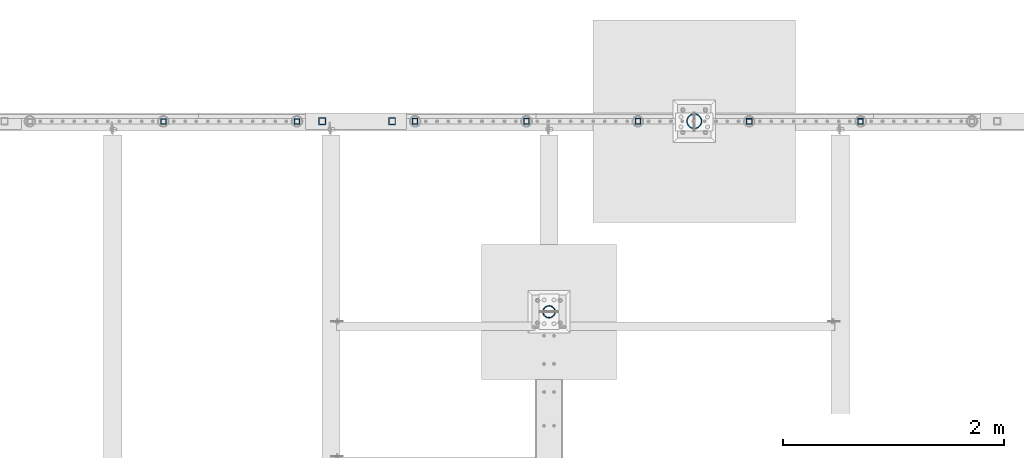
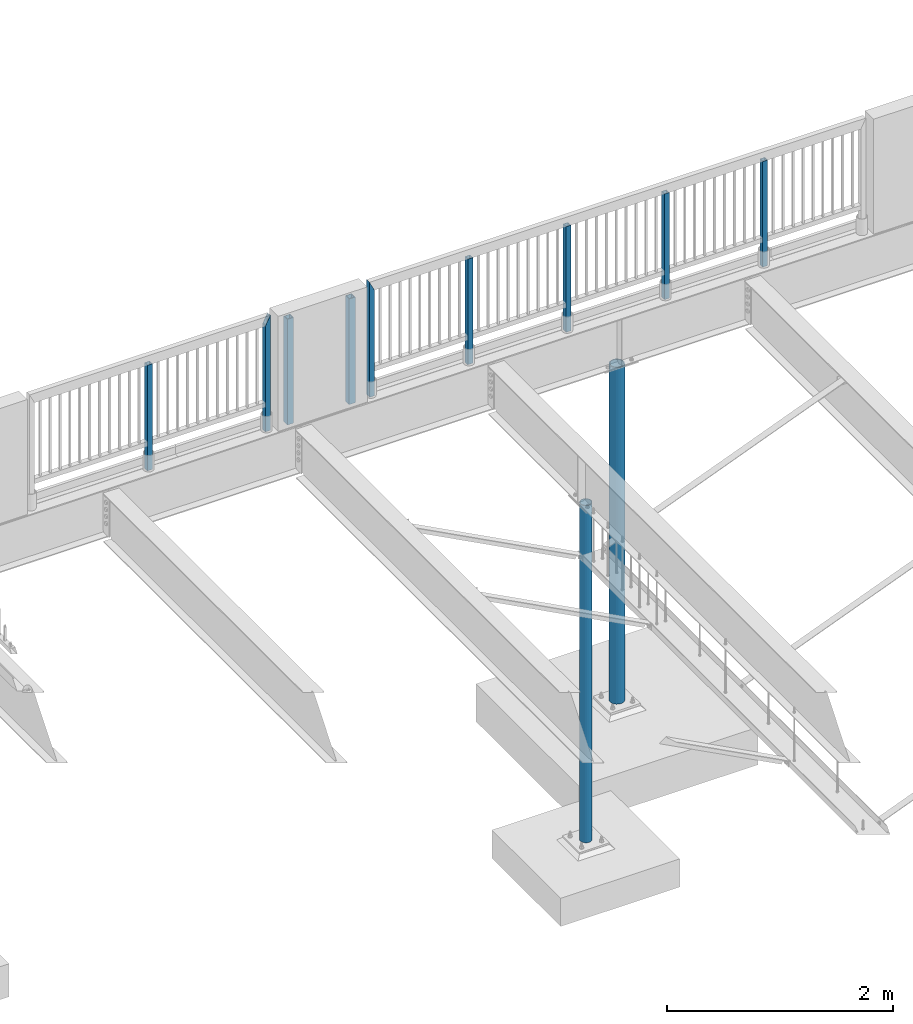
# One storey, part 127 of 975: 11 columns.
"""IFC2X3 building model written with IfcOpenShell, lengths in millimetres."""

from ifc_helpers import new_model, si_unit, frame, origin_with_axes, place, context, subcontext, project, spatial, faceted_brep, material, type_object, element, save


model = new_model("IFC2X3")

# Units and contexts
model_context = context("Model", 3, precision=1e-05, world=origin_with_axes())
body_context = subcontext(model_context, "Body", "Model", "MODEL_VIEW")
ifc_project = project(units=[si_unit("LENGTHUNIT", "METRE", prefix="MILLI"), si_unit("AREAUNIT", "SQUARE_METRE"), si_unit("VOLUMEUNIT", "CUBIC_METRE"), si_unit("MASSUNIT", "GRAM", prefix="KILO"), si_unit("TIMEUNIT", "SECOND"), si_unit("PLANEANGLEUNIT", "RADIAN"), si_unit("SOLIDANGLEUNIT", "STERADIAN"), si_unit("THERMODYNAMICTEMPERATUREUNIT", "DEGREE_CELSIUS"), si_unit("LUMINOUSINTENSITYUNIT", "LUMEN")], contexts=[model_context])

# Site, building, storey
site_placement = place(None, origin_with_axes())
site = spatial("IfcSite", under=ifc_project, at=site_placement, CompositionType="ELEMENT")
building_placement = place(site_placement, origin_with_axes())
building = spatial("IfcBuilding", under=site, at=building_placement, Name="Undefined", CompositionType="ELEMENT")
storey_placement = place(building_placement, origin_with_axes())
storey = spatial("IfcBuildingStorey", under=building, at=storey_placement, Name="Undefined", CompositionType="ELEMENT", Elevation=0.0)

# Columns
ifc_material_1 = material()
column_type_1 = type_object("IfcColumnType", Name="HSS2X2X.188_TUBES", PredefinedType="NOTDEFINED")
column_1_placement = place(storey_placement, frame((4746.62702976621, 29961.7244176431, 3937.0), z_axis=(1.0, 0.0, 0.0), x_axis=(0.0, 0.0, 1.0)))
element("IfcColumn", 1, at=column_1_placement, inside=storey, type_object=column_type_1, material=ifc_material_1, Name="HANDRAIL", ObjectType="HSS2X2X.188_TUBES", context=body_context, shape_type="Brep", body=[
    faceted_brep([(0.0, 20.6374999999753, -20.6375000000298), (0.0, -20.6375000000153, -20.6375000000153), (1142.99998821453, -20.6374999999462, -20.6374999999534), (1142.99998821453, 20.6374999999462, -20.6374999999516), (0.0, -20.6374999999825, 20.6375000000335), (1142.9999881907, -20.6375000000262, 20.6375000000335), (0.0, 20.6375000000116, 20.6375000000189), (1142.99998829488, 20.6375000000335, 20.637500000048), (0.0, 25.3999999999724, -25.4000000000342), (0.0, 25.400000000016, 25.4000000000196), (1143.0, 25.4000000000051, 25.4000000000378), (1143.0, 25.4000000000433, -25.4000000000087), (0.0, -25.399999999976, 25.4000000000378), (1143.0, -25.4000000000451, 25.4000000000087), (0.0, -25.400000000016, -25.4000000000196), (1143.0, -25.4000000000106, -25.4000000000451)], [[[0, 1, 2, 3]], [[1, 4, 5, 2]], [[4, 6, 7, 5]], [[6, 0, 3, 7]], [[8, 9, 10, 11]], [[9, 12, 13, 10]], [[12, 14, 15, 13]], [[14, 8, 11, 15]], [[13, 15, 11, 10], [5, 7, 3, 2]], [[14, 12, 9, 8], [6, 4, 1, 0]]]),
])
column_2_placement = place(storey_placement, frame((5953.13079488792, 29961.6812945025, 3937.00002018607), z_axis=(1.0, 0.0, 0.0), x_axis=(0.0, 0.0, 1.0)))
element("IfcColumn", 2, at=column_2_placement, inside=storey, type_object=column_type_1, material=ifc_material_1, Name="HANDRAIL", ObjectType="HSS2X2X.188_TUBES", context=body_context, shape_type="Brep", body=[
    faceted_brep([(0.0, 20.6374999999753, -20.6375000000298), (0.0, -20.6375000000153, -20.6375000000153), (1152.52497983932, -20.6374999999462, -20.6374999999525), (1152.52900291014, 20.6374999999462, -20.6374999999489), (0.0, -20.6374999999825, 20.6375000000335), (1235.07090617935, -20.6375000000007, 20.6374999994514), (0.0, 20.6375000000116, 20.6375000000189), (1235.07497982248, 20.6374999999534, 20.6374999999471), (0.0, 25.3999999999724, -25.4000000000342), (0.0, 25.400000000016, 25.4000000000196), (1244.59997982054, 25.399999999936, 25.3999999999351), (1143.00499212253, 25.4000000000015, -25.4000000005071), (0.0, -25.399999999976, 25.4000000000378), (1244.59496625419, -25.4000000000015, 25.3999999994476), (0.0, -25.400000000016, -25.4000000000196), (1143.0, -25.4000000000106, -25.4000000000451)], [[[0, 1, 2, 3]], [[1, 4, 5, 2]], [[4, 6, 7, 5]], [[6, 0, 3, 7]], [[8, 9, 10, 11]], [[9, 12, 13, 10]], [[12, 14, 15, 13]], [[14, 8, 11, 15]], [[13, 15, 11, 10], [5, 7, 3, 2]], [[14, 12, 9, 8], [6, 4, 1, 0]]]),
])
for number, where, z_axis, x_axis, name in (
    (3, (11043.2861464828, 29962.001432919, 3937.00000492095), (1.0, 0.0, 0.0), (0.0, 0.0, 1.0), "HANDRAIL"),
    (4, (10037.4463859172, 29962.1353432434, 3937.00000492095), (1.0, 0.0, 0.0), (0.0, 0.0, 1.0), "HANDRAIL"),
    (5, (9031.6066253516, 29962.2692535677, 3937.00000492095), (1.0, 0.0, 0.0), (0.0, 0.0, 1.0), "HANDRAIL"),
    (6, (8025.76686478601, 29962.4031638921, 3937.00000492095), (1.0, 0.0, 0.0), (0.0, 0.0, 1.0), "HANDRAIL"),
):
    element("IfcColumn", number, at=place(storey_placement, frame(where, z_axis=z_axis, x_axis=x_axis)), inside=storey, type_object=column_type_1, material=ifc_material_1, Name=name, ObjectType="HSS2X2X.188_TUBES", context=body_context, shape_type="Brep", body=[
        faceted_brep([(0.0, 20.6374999999753, -20.6375000000298), (0.0, -20.6375000000153, -20.6375000000153), (1142.99168660487, -20.6375000000007, -20.6374999992804), (1142.99168660487, 20.6375000000007, -20.6374999992804), (0.0, -20.6374999999825, 20.6375000000335), (1142.99171607524, -20.6375000000007, 20.6375000007301), (0.0, 20.6375000000116, 20.6375000000189), (1142.99171607524, 20.6375000000007, 20.6375000007301), (0.0, 25.3999999999724, -25.4000000000342), (0.0, 25.400000000016, 25.4000000000196), (1142.99171947567, 25.4000000000015, 25.4000000007327), (1142.99168320445, 25.4000000000015, -25.3999999992811), (0.0, -25.399999999976, 25.4000000000378), (1142.99171947567, -25.4000000000015, 25.4000000007327), (0.0, -25.400000000016, -25.4000000000196), (1142.99168320445, -25.4000000000015, -25.3999999992811)], [[[0, 1, 2, 3]], [[1, 4, 5, 2]], [[4, 6, 7, 5]], [[6, 0, 3, 7]], [[8, 9, 10, 11]], [[9, 12, 13, 10]], [[12, 14, 15, 13]], [[14, 8, 11, 15]], [[13, 15, 11, 10], [5, 7, 3, 2]], [[14, 12, 9, 8], [6, 4, 1, 0]]]),
    ])
column_3_placement = place(storey_placement, frame((7019.92795664395, 29962.4445423951, 3936.99171804664), z_axis=(1.0, 0.0, 0.0), x_axis=(0.0, 0.0, 1.0)))
element("IfcColumn", 7, at=column_3_placement, inside=storey, type_object=column_type_1, material=ifc_material_1, Name="HANDRAIL", ObjectType="HSS2X2X.188_TUBES", context=body_context, shape_type="Brep", body=[
    faceted_brep([(0.0, 20.6374999999753, -20.6375000000298), (0.0, -20.6375000000153, -20.6375000000153), (1235.074979717, -20.6374999999462, -20.6374999999462), (1235.06811346884, 20.6375000005501, -20.6374999999998), (0.0, -20.6374999999825, 20.6375000000335), (1152.53186299272, -20.6374999994914, 20.6374999999998), (0.0, 20.6375000000116, 20.6375000000189), (1152.52497980387, 20.6374999999534, 20.6374999999534), (0.0, 25.3999999999724, -25.4000000000342), (0.0, 25.400000000016, 25.4000000000196), (1143.0, 25.4000000000051, 25.4000000000378), (1244.59152698532, 25.4000000005508, -25.3999999999996), (0.0, -25.399999999976, 25.4000000000378), (1143.00844947624, -25.3999999994921, 25.3999999999996), (0.0, -25.400000000016, -25.4000000000196), (1244.59997970698, -25.399999999936, -25.399999999936)], [[[0, 1, 2, 3]], [[1, 4, 5, 2]], [[4, 6, 7, 5]], [[6, 0, 3, 7]], [[8, 9, 10, 11]], [[9, 12, 13, 10]], [[12, 14, 15, 13]], [[14, 8, 11, 15]], [[13, 15, 11, 10], [5, 7, 3, 2]], [[14, 12, 9, 8], [6, 4, 1, 0]]]),
])
column_type_2 = type_object("IfcColumnType", Name="HSS2-1/2X2-1/2X1/4", PredefinedType="NOTDEFINED")
for number, where, z_axis, x_axis in (
    (8, (6813.10177610894, 29962.4726654687, 3937.0), (0.0, 1.0, 0.0), (0.0, 0.0, 1.0)),
    (9, (6181.27677605927, 29962.4718869472, 3937.0), (0.0, 1.0, 0.0), (0.0, 0.0, 1.0)),
):
    element("IfcColumn", number, at=place(storey_placement, frame(where, z_axis=z_axis, x_axis=x_axis)), inside=storey, type_object=column_type_2, material=ifc_material_1, ObjectType="HSS2-1/2X2-1/2X1/4", context=body_context, shape_type="Brep", body=[
        faceted_brep([(0.0, 25.3999999999724, -25.4000000000342), (0.0, -25.400000000016, -25.4000000000196), (1143.0, -25.4000000000106, -25.4000000000451), (1143.0, 25.4000000000433, -25.4000000000087), (0.0, -25.399999999976, 25.4000000000378), (1143.0, -25.4000000000451, 25.4000000000087), (0.0, 25.400000000016, 25.4000000000196), (1143.0, 25.4000000000051, 25.4000000000378), (-5.45696821063757e-11, 31.7499999999909, -31.75000000002), (0.0, 31.7500000000127, 31.7500000000582), (1143.0, 31.7500000000127, 31.7500000000582), (1143.0, 31.7500000000546, -31.7500000000146), (0.0, -31.7500000000564, 31.7500000000073), (1143.0, -31.7500000000564, 31.7500000000073), (0.0, -31.7500000000146, -31.7500000000582), (1143.0, -31.7500000000146, -31.7500000000582)], [[[0, 1, 2, 3]], [[1, 4, 5, 2]], [[4, 6, 7, 5]], [[6, 0, 3, 7]], [[8, 9, 10, 11]], [[9, 12, 13, 10]], [[12, 14, 15, 13]], [[14, 8, 11, 15]], [[13, 15, 11, 10], [5, 7, 3, 2]], [[14, 12, 9, 8], [6, 4, 1, 0]]]),
    ])
ifc_material_2 = material(Name="STEEL/A53")
column_type_3 = type_object("IfcColumnType", Name="PIPE4STD", PredefinedType="NOTDEFINED")
column_4_placement = place(storey_placement, frame((8229.6, 28241.625, -266.7), z_axis=(0.0, 1.0, 0.0), x_axis=(0.0, 0.0, 1.0)))
element("IfcColumn", 10, at=column_4_placement, inside=storey, type_object=column_type_3, material=ifc_material_2, Name="COLUMN", ObjectType="PIPE4STD", context=body_context, shape_type="Brep", body=[
    faceted_brep([(19.0500000000025, -51.1301999999996, 0.0), (19.0500000000025, -48.6277098894743, 15.8001007257917), (3667.125, -48.6277098894743, 15.8001007257917), (3667.125, -51.1301999999996, 0.0), (19.0500000000025, -41.3652007257897, 30.0535775067656), (3667.125, -41.3652007257897, 30.0535775067656), (19.0500000000025, -30.0535775067647, 41.3652007257915), (3667.125, -30.0535775067638, 41.3652007257915), (19.0500000000025, -15.8001007257899, 48.6277098894752), (3667.125, -15.8001007257899, 48.6277098894752), (19.0500000000025, 0.0, 51.1301999999996), (3667.125, 0.0, 51.1301999999996), (19.0500000000025, 15.8001007257899, 48.6277098894752), (3667.125, 15.8001007257899, 48.6277098894752), (19.0500000000025, 30.0535775067647, 41.3652007257915), (3667.125, 30.0535775067638, 41.3652007257915), (19.0500000000025, 41.3652007257897, 30.0535775067656), (3667.125, 41.3652007257897, 30.0535775067656), (19.0500000000025, 48.6277098894743, 15.8001007257917), (3667.125, 48.6277098894752, 15.8001007257917), (19.0500000000025, 51.1301999999996, 0.0), (3667.125, 51.1301999999996, 0.0), (19.0500000000025, 48.6277098894743, -15.8001007257917), (3667.125, 48.6277098894752, -15.8001007257917), (19.0500000000025, 41.3652007257897, -30.0535775067656), (3667.125, 41.3652007257897, -30.0535775067656), (19.0500000000025, 30.0535775067647, -41.3652007257915), (3667.125, 30.0535775067638, -41.3652007257915), (19.0500000000025, 15.8001007257899, -48.6277098894752), (3667.125, 15.8001007257899, -48.6277098894752), (19.0500000000025, 0.0, -51.1301999999996), (3667.125, 0.0, -51.1301999999996), (19.0500000000025, -15.8001007257899, -48.6277098894752), (3667.125, -15.8001007257899, -48.6277098894752), (19.0500000000025, -30.0535775067647, -41.3652007257915), (3667.125, -30.0535775067638, -41.3652007257915), (19.0500000000025, -41.3652007257897, -30.0535775067656), (3667.125, -41.3652007257897, -30.0535775067656), (19.0500000000025, -48.6277098894743, -15.8001007257917), (3667.125, -48.6277098894743, -15.8001007257917), (19.0500000000025, -57.1499999999996, 0.0), (19.0500000000025, -54.3528799062678, -17.6603212285299), (3667.125, -54.3528799062678, -17.6603212285299), (3667.125, -57.1499999999996, 0.0), (19.0500000000025, -46.2353212285279, -33.5919271685161), (3667.125, -46.2353212285279, -33.5919271685161), (19.0500000000025, -33.5919271685152, -46.235321228527), (3667.125, -33.5919271685143, -46.235321228527), (19.0500000000025, -17.6603212285281, -54.3528799062697), (3667.125, -17.6603212285281, -54.3528799062697), (19.0500000000025, 0.0, -57.1500000000015), (3667.125, 0.0, -57.1500000000015), (19.0500000000025, 17.6603212285281, -54.3528799062697), (3667.125, 17.6603212285281, -54.3528799062697), (19.0500000000025, 33.5919271685152, -46.235321228527), (3667.125, 33.5919271685143, -46.235321228527), (19.0500000000025, 46.2353212285279, -33.5919271685161), (3667.125, 46.2353212285288, -33.5919271685161), (19.0500000000025, 54.3528799062678, -17.6603212285299), (3667.125, 54.3528799062678, -17.6603212285299), (19.0500000000025, 57.1499999999996, 0.0), (3667.125, 57.1499999999996, 0.0), (19.0500000000025, 54.3528799062678, 17.6603212285299), (3667.125, 54.3528799062678, 17.6603212285299), (19.0500000000025, 46.2353212285279, 33.5919271685161), (3667.125, 46.2353212285288, 33.5919271685161), (19.0500000000025, 33.5919271685152, 46.235321228527), (3667.125, 33.5919271685143, 46.235321228527), (19.0500000000025, 17.6603212285281, 54.3528799062697), (3667.125, 17.6603212285281, 54.3528799062697), (19.0500000000025, 0.0, 57.1500000000015), (3667.125, 0.0, 57.1500000000015), (19.0500000000025, -17.6603212285281, 54.3528799062697), (3667.125, -17.6603212285281, 54.3528799062697), (19.0500000000025, -33.5919271685152, 46.235321228527), (3667.125, -33.5919271685143, 46.235321228527), (19.0500000000025, -46.2353212285279, 33.5919271685161), (3667.125, -46.2353212285279, 33.5919271685161), (19.0500000000025, -54.3528799062678, 17.6603212285299), (3667.125, -54.3528799062678, 17.6603212285299)], [[[0, 1, 2, 3]], [[1, 4, 5, 2]], [[4, 6, 7, 5]], [[6, 8, 9, 7]], [[8, 10, 11, 9]], [[10, 12, 13, 11]], [[12, 14, 15, 13]], [[14, 16, 17, 15]], [[16, 18, 19, 17]], [[18, 20, 21, 19]], [[20, 22, 23, 21]], [[22, 24, 25, 23]], [[24, 26, 27, 25]], [[26, 28, 29, 27]], [[28, 30, 31, 29]], [[30, 32, 33, 31]], [[32, 34, 35, 33]], [[34, 36, 37, 35]], [[36, 38, 39, 37]], [[38, 0, 3, 39]], [[40, 41, 42, 43]], [[41, 44, 45, 42]], [[44, 46, 47, 45]], [[46, 48, 49, 47]], [[48, 50, 51, 49]], [[50, 52, 53, 51]], [[52, 54, 55, 53]], [[54, 56, 57, 55]], [[56, 58, 59, 57]], [[58, 60, 61, 59]], [[60, 62, 63, 61]], [[62, 64, 65, 63]], [[64, 66, 67, 65]], [[66, 68, 69, 67]], [[68, 70, 71, 69]], [[70, 72, 73, 71]], [[72, 74, 75, 73]], [[74, 76, 77, 75]], [[76, 78, 79, 77]], [[78, 40, 43, 79]], [[45, 47, 49, 51, 53, 55, 57, 59, 61, 63, 65, 67, 69, 71, 73, 75, 77, 79, 43, 42], [5, 7, 9, 11, 13, 15, 17, 19, 21, 23, 25, 27, 29, 31, 33, 35, 37, 39, 3, 2]], [[78, 76, 74, 72, 70, 68, 66, 64, 62, 60, 58, 56, 54, 52, 50, 48, 46, 44, 41, 40], [38, 36, 34, 32, 30, 28, 26, 24, 22, 20, 18, 16, 14, 12, 10, 8, 6, 4, 1, 0]]]),
])
column_type_4 = type_object("IfcColumnType", Name="PIPE5XS", PredefinedType="NOTDEFINED")
column_5_placement = place(storey_placement, frame((9540.875, 29962.475, -266.7), z_axis=(0.0, 1.0, 0.0), x_axis=(0.0, 0.0, 1.0)))
element("IfcColumn", 11, at=column_5_placement, inside=storey, type_object=column_type_4, material=ifc_material_2, Name="COLUMN", ObjectType="PIPE5XS", context=body_context, shape_type="Brep", body=[
    faceted_brep([(25.3999999999999, -61.0869999999995, 0.0), (25.3999999999999, -58.0971894109207, 18.8769211353829), (3667.125, -58.0971894109225, 18.8769211353829), (3667.125, -61.0869999999995, 0.0), (25.3999999999999, -49.4204211353826, 35.9060377067908), (3667.125, -49.4204211353826, 35.9060377067908), (25.3999999999999, -35.9060377067908, 49.4204211353826), (3667.125, -35.9060377067908, 49.4204211353826), (25.3999999999999, -18.8769211353829, 58.0971894109225), (3667.125, -18.8769211353829, 58.0971894109207), (25.3999999999999, 0.0, 61.0869999999995), (3667.125, 0.0, 61.0869999999995), (25.3999999999999, 18.8769211353829, 58.0971894109225), (3667.125, 18.8769211353829, 58.0971894109207), (25.3999999999999, 35.9060377067908, 49.4204211353826), (3667.125, 35.9060377067908, 49.4204211353826), (25.3999999999999, 49.4204211353826, 35.9060377067908), (3667.125, 49.4204211353826, 35.9060377067908), (25.3999999999999, 58.0971894109207, 18.8769211353829), (3667.125, 58.0971894109225, 18.8769211353829), (25.3999999999999, 61.0869999999995, 0.0), (3667.125, 61.0869999999995, 0.0), (25.3999999999999, 58.0971894109207, -18.8769211353829), (3667.125, 58.0971894109225, -18.8769211353829), (25.3999999999999, 49.4204211353826, -35.9060377067908), (3667.125, 49.4204211353826, -35.9060377067908), (25.3999999999999, 35.9060377067908, -49.4204211353826), (3667.125, 35.9060377067908, -49.4204211353826), (25.3999999999999, 18.8769211353829, -58.0971894109225), (3667.125, 18.8769211353829, -58.0971894109207), (25.3999999999999, 0.0, -61.0869999999995), (3667.125, 0.0, -61.0869999999995), (25.3999999999999, -18.8769211353829, -58.0971894109225), (3667.125, -18.8769211353829, -58.0971894109207), (25.3999999999999, -35.9060377067908, -49.4204211353826), (3667.125, -35.9060377067908, -49.4204211353826), (25.3999999999999, -49.4204211353826, -35.9060377067908), (3667.125, -49.4204211353826, -35.9060377067908), (25.3999999999999, -58.0971894109207, -18.8769211353829), (3667.125, -58.0971894109225, -18.8769211353829), (25.3999999999999, -70.612000000001, 0.0), (25.3999999999999, -67.1560027286323, -21.8203080068042), (3667.125, -67.1560027286341, -21.8203080068051), (3667.125, -70.6119999999992, 0.0), (25.3999999999999, -57.126308006802, -41.5046922348765), (3667.125, -57.1263080068038, -41.5046922348774), (25.3999999999999, -41.5046922348774, -57.1263080068038), (3667.125, -41.5046922348756, -57.126308006802), (25.3999999999999, -21.8203080068051, -67.1560027286332), (3667.125, -21.8203080068033, -67.1560027286323), (25.3999999999999, 0.0, -70.6120000000001), (3667.125, 0.0, -70.612000000001), (25.3999999999999, 21.8203080068051, -67.1560027286332), (3667.125, 21.8203080068033, -67.1560027286323), (25.3999999999999, 41.5046922348774, -57.1263080068038), (3667.125, 41.5046922348756, -57.126308006802), (25.3999999999999, 57.126308006802, -41.5046922348765), (3667.125, 57.1263080068038, -41.5046922348774), (25.3999999999999, 67.1560027286323, -21.8203080068042), (3667.125, 67.1560027286341, -21.8203080068051), (25.3999999999999, 70.612000000001, 0.0), (3667.125, 70.6119999999992, 0.0), (25.3999999999999, 67.1560027286323, 21.8203080068042), (3667.125, 67.1560027286341, 21.8203080068051), (25.3999999999999, 57.126308006802, 41.5046922348765), (3667.125, 57.1263080068038, 41.5046922348774), (25.3999999999999, 41.5046922348774, 57.1263080068038), (3667.125, 41.5046922348756, 57.126308006802), (25.3999999999999, 21.8203080068051, 67.1560027286332), (3667.125, 21.8203080068033, 67.1560027286323), (25.3999999999999, 0.0, 70.6120000000001), (3667.125, 0.0, 70.612000000001), (25.3999999999999, -21.8203080068051, 67.1560027286332), (3667.125, -21.8203080068033, 67.1560027286323), (25.3999999999999, -41.5046922348774, 57.1263080068038), (3667.125, -41.5046922348756, 57.126308006802), (25.3999999999999, -57.126308006802, 41.5046922348765), (3667.125, -57.1263080068038, 41.5046922348774), (25.3999999999999, -67.1560027286323, 21.8203080068042), (3667.125, -67.1560027286341, 21.8203080068051)], [[[0, 1, 2, 3]], [[1, 4, 5, 2]], [[4, 6, 7, 5]], [[6, 8, 9, 7]], [[8, 10, 11, 9]], [[10, 12, 13, 11]], [[12, 14, 15, 13]], [[14, 16, 17, 15]], [[16, 18, 19, 17]], [[18, 20, 21, 19]], [[20, 22, 23, 21]], [[22, 24, 25, 23]], [[24, 26, 27, 25]], [[26, 28, 29, 27]], [[28, 30, 31, 29]], [[30, 32, 33, 31]], [[32, 34, 35, 33]], [[34, 36, 37, 35]], [[36, 38, 39, 37]], [[38, 0, 3, 39]], [[40, 41, 42, 43]], [[41, 44, 45, 42]], [[44, 46, 47, 45]], [[46, 48, 49, 47]], [[48, 50, 51, 49]], [[50, 52, 53, 51]], [[52, 54, 55, 53]], [[54, 56, 57, 55]], [[56, 58, 59, 57]], [[58, 60, 61, 59]], [[60, 62, 63, 61]], [[62, 64, 65, 63]], [[64, 66, 67, 65]], [[66, 68, 69, 67]], [[68, 70, 71, 69]], [[70, 72, 73, 71]], [[72, 74, 75, 73]], [[74, 76, 77, 75]], [[76, 78, 79, 77]], [[78, 40, 43, 79]], [[45, 47, 49, 51, 53, 55, 57, 59, 61, 63, 65, 67, 69, 71, 73, 75, 77, 79, 43, 42], [5, 7, 9, 11, 13, 15, 17, 19, 21, 23, 25, 27, 29, 31, 33, 35, 37, 39, 3, 2]], [[78, 76, 74, 72, 70, 68, 66, 64, 62, 60, 58, 56, 54, 52, 50, 48, 46, 44, 41, 40], [38, 36, 34, 32, 30, 28, 26, 24, 22, 20, 18, 16, 14, 12, 10, 8, 6, 4, 1, 0]]]),
])

save(model, "model.ifc")
